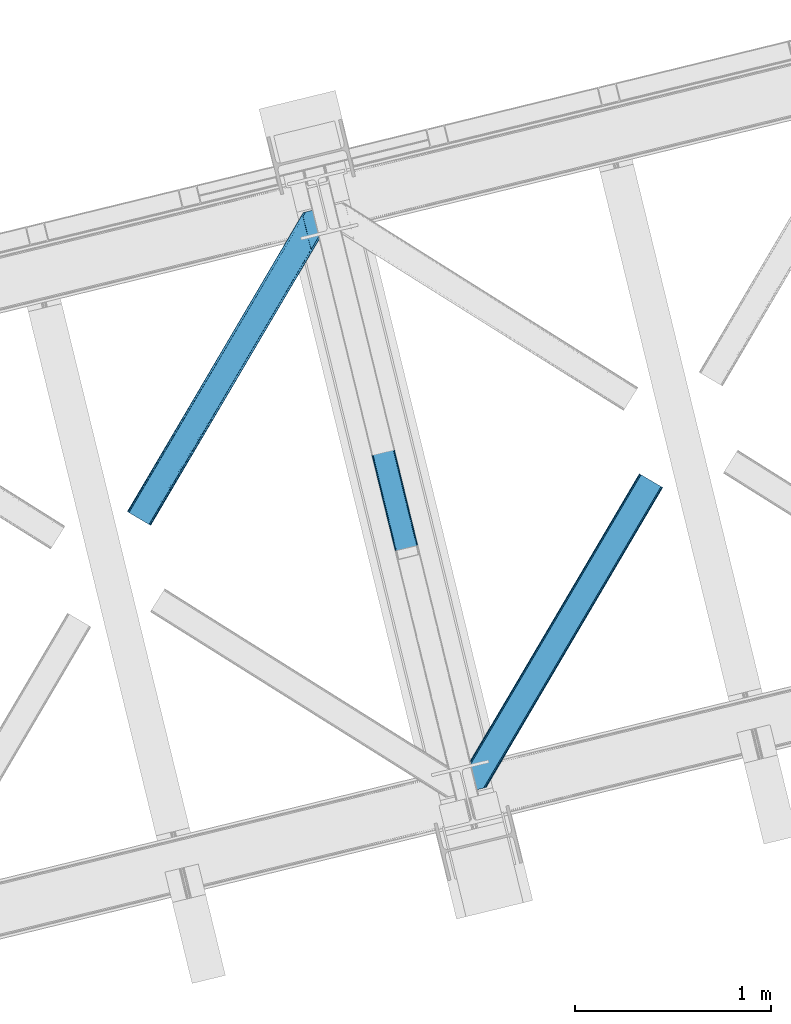
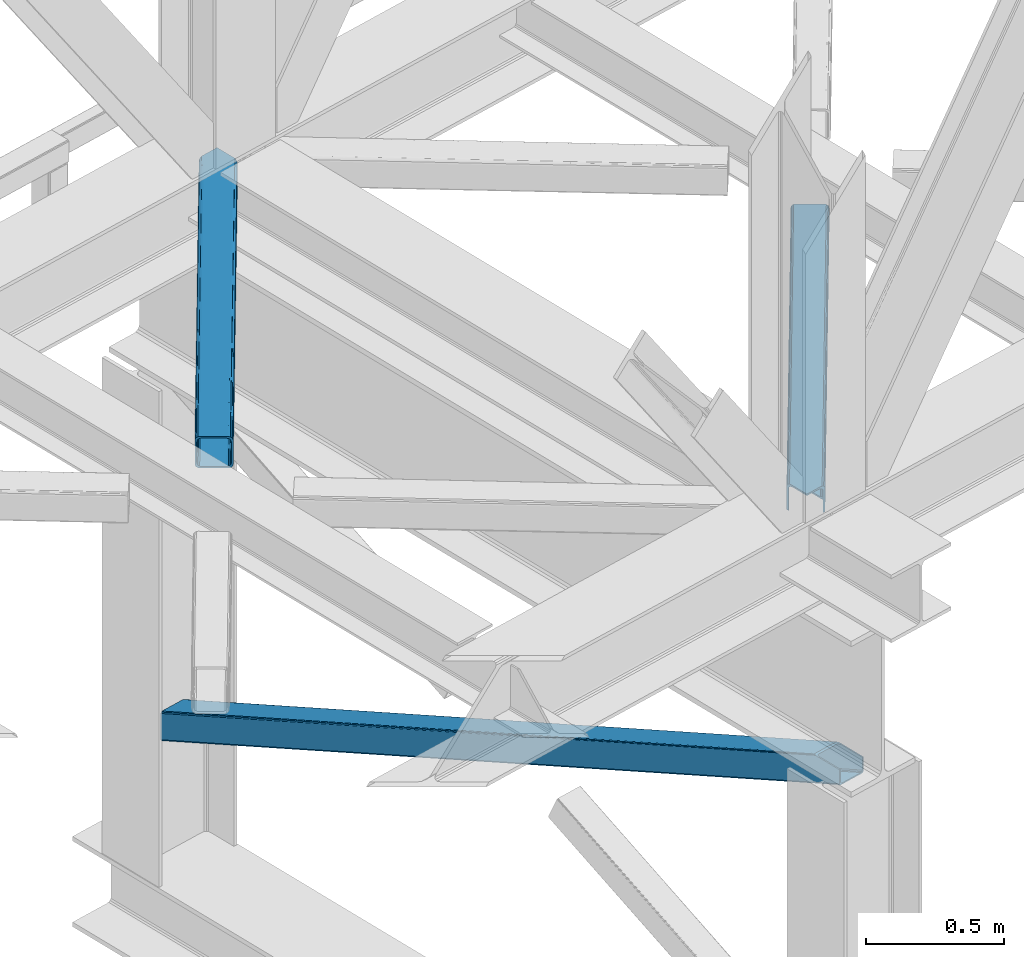
# One storey, part 30 of 92: 3 members.
"""IFC4 building model written with IfcOpenShell, lengths in millimetres."""

from ifc_helpers import new_model, entity, si_unit, converted_unit, derived_unit, direction, frame, origin, place, context, subcontext, project, spatial, triangles, type_object, element, save


model = new_model("IFC4")

# Units and contexts
model_context = context("Model", 3, precision=0.01, world=origin(), true_north=direction((6.12303176911189e-17, 1.0)))
plan_context = context("Plan", 3, precision=0.01, world=origin(), true_north=direction((6.12303176911189e-17, 1.0)))
body_context = subcontext(model_context, "Body", "Model", "MODEL_VIEW")
ifc_project = project(units=[si_unit("LENGTHUNIT", "METRE", prefix="MILLI"), si_unit("AREAUNIT", "SQUARE_METRE"), si_unit("VOLUMEUNIT", "CUBIC_METRE"), converted_unit("PLANEANGLEUNIT", "DEGREE", entity("IfcRatioMeasure", 0.0174532925199433), si_unit("PLANEANGLEUNIT", "RADIAN"), dimensions=[0, 0, 0, 0, 0, 0, 0]), si_unit("MASSUNIT", "GRAM", prefix="KILO"), derived_unit("MASSDENSITYUNIT", [(si_unit("MASSUNIT", "GRAM", prefix="KILO"), 1), (si_unit("LENGTHUNIT", "METRE"), -3)]), derived_unit("MOMENTOFINERTIAUNIT", [(si_unit("LENGTHUNIT", "METRE"), 4)]), si_unit("TIMEUNIT", "SECOND"), si_unit("FREQUENCYUNIT", "HERTZ"), si_unit("THERMODYNAMICTEMPERATUREUNIT", "DEGREE_CELSIUS"), derived_unit("THERMALTRANSMITTANCEUNIT", [(si_unit("MASSUNIT", "GRAM", prefix="KILO"), 1), (si_unit("THERMODYNAMICTEMPERATUREUNIT", "KELVIN"), -1), (si_unit("TIMEUNIT", "SECOND"), -3)]), derived_unit("VOLUMETRICFLOWRATEUNIT", [(si_unit("LENGTHUNIT", "METRE"), 3), (si_unit("TIMEUNIT", "SECOND"), -1)]), derived_unit("MASSFLOWRATEUNIT", [(si_unit("MASSUNIT", "GRAM", prefix="KILO"), 1), (si_unit("TIMEUNIT", "SECOND"), -1)]), derived_unit("ROTATIONALFREQUENCYUNIT", [(si_unit("TIMEUNIT", "SECOND"), -1)]), si_unit("ELECTRICCURRENTUNIT", "AMPERE"), si_unit("ELECTRICVOLTAGEUNIT", "VOLT"), si_unit("POWERUNIT", "WATT"), si_unit("FORCEUNIT", "NEWTON", prefix="KILO"), si_unit("ILLUMINANCEUNIT", "LUX"), si_unit("LUMINOUSFLUXUNIT", "LUMEN"), si_unit("LUMINOUSINTENSITYUNIT", "CANDELA"), derived_unit("USERDEFINED", [(si_unit("MASSUNIT", "GRAM", prefix="KILO"), -1), (si_unit("LENGTHUNIT", "METRE"), -2), (si_unit("TIMEUNIT", "SECOND"), 3), (si_unit("LUMINOUSFLUXUNIT", "LUMEN"), 1)]), derived_unit("LINEARVELOCITYUNIT", [(si_unit("LENGTHUNIT", "METRE"), 1), (si_unit("TIMEUNIT", "SECOND"), -1)]), si_unit("PRESSUREUNIT", "PASCAL"), derived_unit("USERDEFINED", [(si_unit("LENGTHUNIT", "METRE"), -2), (si_unit("MASSUNIT", "GRAM", prefix="KILO"), 1), (si_unit("TIMEUNIT", "SECOND"), -2)]), derived_unit("LINEARFORCEUNIT", [(si_unit("MASSUNIT", "GRAM", prefix="KILO"), 1), (si_unit("LENGTHUNIT", "METRE"), 1), (si_unit("TIMEUNIT", "SECOND"), -2), (si_unit("LENGTHUNIT", "METRE"), -1)]), derived_unit("PLANARFORCEUNIT", [(si_unit("MASSUNIT", "GRAM", prefix="KILO"), 1), (si_unit("LENGTHUNIT", "METRE"), 1), (si_unit("TIMEUNIT", "SECOND"), -2), (si_unit("LENGTHUNIT", "METRE"), -2)])], contexts=[model_context, plan_context])

# Site, building, storey
site_placement = place(None, origin())
site = spatial("IfcSite", under=ifc_project, at=site_placement, CompositionType="ELEMENT")
building_placement = place(site_placement, origin())
building = spatial("IfcBuilding", under=site, at=building_placement, CompositionType="ELEMENT")
storey_placement = place(building_placement, frame((0.0, 0.0, 15900.0)))
storey = spatial("IfcBuildingStorey", under=building, at=storey_placement, Name="05", CompositionType="ELEMENT", Elevation=15900.0)

# Members
member_type_1 = type_object("IfcMemberType", PredefinedType="BRACE")
member_1_placement = place(storey_placement, frame((-55294.26, 4087.91, 911.28)))
element("IfcMember", 1, at=member_1_placement, inside=storey, type_object=member_type_1, ObjectType="Steel Vertical Brace", PredefinedType="BRACE", context=body_context, shape_type="Tessellation", body=[
    triangles([(109.783996582031, 3493.74488525391, 0.0), (954.899853515621, 26.7611572265623, 1610.78191223144), (6.79958496093604, 3468.64118499756, 0.0), (851.915441894525, 1.65774765014658, 1610.78191223144), (112.188500976561, 3494.33089599609, 1.12551269531104), (957.30435791015, 27.3474586486818, 1611.90626220703), (114.593005371091, 3494.91690673828, 2.24986267089844), (959.708862304688, 27.9334693908695, 1613.03061218261), (115.588293457025, 3495.15991516113, 4.96481323242188), (960.704150390622, 28.1761871337894, 1615.74672546387), (116.588232421869, 3495.40234222412, 7.68092651366896), (961.699438476557, 28.4189048767093, 1618.46167602539), (0.99528808593459, 3467.22615509033, 4.96481323242188), (846.111145019531, 0.242717742919922, 1615.74672546387), (0.0, 3466.98372802734, 7.68092651366896), (845.115856933589, 0.0, 1618.46167602539), (1.99057617186918, 3467.46916351318, 2.24986267089844), (847.106433105466, 0.485435485839844, 1613.03061218261), (4.39508056640625, 3468.05517425537, 1.12551269531104), (849.510937499996, 1.07144622802753, 1611.90626220703), (933.347680664061, 144.732444763184, 1680.7206665039), (116.588232421869, 3495.40234222412, 123.979641723632), (961.699438476557, 28.4189048767093, 1680.7206665039), (816.759448242185, 116.313539886474, 1680.7206665039), (0.0, 3466.98372802734, 123.979641723632), (845.115856933589, 0.0, 1680.7206665039), (112.188500976561, 3494.33089599609, 130.53505554199), (109.783996582031, 3493.74488525391, 131.659405517577), (922.5157836914, 159.605083465576, 1680.7206665039), (114.593005371091, 3494.91690673828, 129.409542846679), (925.427233886716, 158.980993652343, 1680.7206665039), (115.588293457025, 3495.15991516113, 126.694592285156), (928.506115722652, 155.935830688477, 1680.7206665039), (931.287341308591, 150.932357025146, 1680.7206665039), (6.79958496093604, 3468.64118499756, 131.659405517577), (819.531372070313, 134.501383209228, 1680.7206665039), (815.73625488281, 122.76547164917, 1680.7206665039), (0.99528808593459, 3467.22615509033, 126.694592285156), (815.903686523438, 128.487506103515, 1680.7206665039), (1.99057617186918, 3467.46916351318, 129.409542846679), (817.23848876953, 132.608766174317, 1680.7206665039), (4.39508056640625, 3468.05517425537, 130.53505554199), (923.44595947265, 145.989635467529, 1680.7206665039), (926.524841308594, 142.94418182373, 1680.7206665039), (920.539160156244, 146.61343460083, 1680.7206665039), (931.366406249996, 131.74108657837, 1680.7206665039), (956.843920898435, 27.2349655151365, 1680.7206665039), (929.306066894525, 137.9407081604, 1680.7206665039), (823.638098144525, 117.864317321777, 1680.7206665039), (824.972900390625, 121.985577392578, 1680.7206665039), (827.27043457031, 123.878194427491, 1680.7206665039), (824.498510742182, 105.690060424805, 1680.7206665039), (823.475317382807, 112.142282867431, 1680.7206665039), (849.971374511719, 1.18393936157236, 1680.7206665039), (111.728063964838, 3494.21869354248, 118.492767333984), (110.732775878903, 3493.97568511963, 121.208880615231), (109.737487792969, 3493.73267669678, 123.923831176755), (107.332983398432, 3493.14666595459, 125.048181152342), (104.928479003902, 3492.5606552124, 126.173693847653), (11.6597534179673, 3469.82541503906, 126.173693847653), (9.2552490234375, 3469.23940429688, 125.048181152342), (6.85074462890043, 3468.65339355469, 123.923831176755), (5.85545654296584, 3468.41038513184, 121.208880615231), (4.85551757812209, 3468.16737670898, 118.492767333984), (111.728063964838, 3494.21869354248, 13.166638183593), (956.843920898435, 27.2349655151365, 1623.94738769531), (4.85551757812209, 3468.16737670898, 13.166638183593), (849.971374511719, 1.18393936157236, 1623.94738769531), (109.737487792969, 3493.73267669678, 7.73557434081886), (107.332983398432, 3493.14666595459, 6.61122436523146), (110.732775878903, 3493.97568511963, 10.4505249023423), (104.928479003902, 3492.5606552124, 5.48571166992042), (6.85074462890043, 3468.65339355469, 7.73557434081886), (5.85545654296584, 3468.41038513184, 10.4505249023423), (9.2552490234375, 3469.23940429688, 6.61122436523146), (11.6597534179673, 3469.82541503906, 5.48571166992042), (950.039685058589, 25.5772178649904, 1616.26762390137), (952.444189453119, 26.1632286071781, 1617.39197387695), (954.848693847656, 26.7492393493649, 1618.51748657227), (856.770959472655, 2.8419776916503, 1616.26762390137), (854.366455078125, 2.25567626953125, 1617.39197387695), (851.961950683588, 1.66966552734357, 1618.51748657227), (955.8486328125, 26.9922477722166, 1621.23243713379), (850.966662597653, 1.42665710449228, 1621.23243713379)], [[1, 2, 3], [4, 3, 2], [5, 6, 2], [2, 1, 5], [7, 8, 6], [6, 5, 7], [9, 10, 8], [8, 7, 9], [11, 12, 10], [10, 9, 11], [13, 14, 15], [16, 15, 14], [17, 18, 13], [14, 13, 18], [19, 20, 17], [18, 17, 20], [3, 4, 19], [20, 19, 4], [11, 21, 12], [21, 11, 22], [23, 12, 21], [24, 15, 16], [24, 25, 15], [16, 26, 24], [27, 28, 29], [30, 27, 31], [32, 30, 33], [22, 32, 34], [34, 21, 22], [33, 34, 32], [31, 33, 30], [29, 31, 27], [29, 28, 35], [35, 36, 29], [25, 24, 37], [38, 37, 39], [40, 39, 41], [42, 41, 36], [36, 35, 42], [41, 42, 40], [39, 40, 38], [37, 38, 25], [43, 44, 34], [33, 43, 34], [29, 33, 31], [45, 29, 36], [33, 45, 43], [29, 45, 33], [44, 21, 34], [23, 46, 47], [23, 21, 46], [44, 48, 21], [48, 46, 21], [37, 49, 50], [36, 51, 45], [51, 39, 50], [39, 51, 36], [50, 39, 37], [39, 36, 41], [24, 49, 37], [52, 53, 24], [53, 49, 24], [52, 26, 54], [24, 26, 52], [55, 46, 48], [56, 48, 44], [57, 44, 43], [58, 43, 45], [45, 59, 58], [43, 58, 57], [44, 57, 56], [48, 56, 55], [59, 45, 51], [51, 60, 59], [61, 60, 51], [62, 61, 50], [63, 62, 49], [64, 63, 53], [53, 52, 64], [49, 53, 63], [50, 49, 62], [51, 50, 61], [46, 65, 66], [46, 55, 65], [66, 47, 46], [67, 52, 68], [52, 67, 64], [54, 68, 52], [58, 59, 28], [32, 57, 27], [32, 27, 30], [28, 59, 35], [28, 27, 58], [57, 58, 27], [55, 22, 11], [22, 56, 57], [55, 56, 22], [22, 57, 32], [42, 62, 38], [60, 35, 59], [61, 42, 35], [61, 35, 60], [38, 40, 42], [62, 25, 38], [42, 61, 62], [62, 63, 25], [25, 64, 15], [64, 25, 63], [69, 5, 70], [11, 65, 55], [71, 11, 69], [11, 71, 65], [69, 11, 9], [70, 1, 72], [69, 9, 5], [5, 9, 7], [72, 1, 3], [5, 1, 70], [73, 13, 15], [74, 73, 15], [75, 19, 73], [67, 15, 64], [15, 67, 74], [19, 13, 73], [3, 76, 72], [19, 75, 3], [76, 3, 75], [17, 13, 19], [77, 4, 2], [2, 6, 78], [6, 8, 10], [6, 79, 78], [2, 78, 77], [79, 6, 10], [80, 4, 77], [18, 20, 14], [20, 4, 81], [81, 82, 20], [20, 82, 14], [80, 81, 4], [14, 82, 16], [83, 12, 66], [10, 12, 79], [83, 79, 12], [23, 66, 12], [23, 47, 66], [16, 84, 68], [84, 16, 82], [68, 26, 16], [26, 68, 54], [77, 72, 76], [76, 80, 77], [66, 65, 83], [71, 83, 65], [83, 71, 79], [69, 79, 71], [79, 69, 78], [70, 78, 69], [78, 70, 77], [72, 77, 70], [80, 76, 75], [75, 81, 80], [81, 75, 73], [73, 82, 81], [82, 73, 74], [74, 84, 82], [84, 74, 67], [67, 68, 84]]),
])
member_type_2 = type_object("IfcMemberType", PredefinedType="BRACE")
member_2_placement = place(storey_placement, frame((-56177.58, 5705.47, 3511.0)))
element("IfcMember", 2, at=member_2_placement, inside=storey, type_object=member_type_2, ObjectType="Steel Horizontal Brace", PredefinedType="BRACE", context=body_context, shape_type="Tessellation", body=[
    triangles([(105.560998535155, 8.87794647216833, 0.0), (15.078149414061, 62.148532104492, 0.0), (892.843176269533, 1346.13992614746, 0.0), (857.166284179686, 1492.50250396729, 0.0), (854.892004394533, 1501.83739929199, 1.33247680664135), (9.30640869140916, 65.5459991455082, 1.33247680664135), (852.961889648439, 1509.75145111084, 5.12526855468968), (4.41368408202834, 68.4266372680668, 5.12526855468968), (851.673596191409, 1515.03950042725, 10.8028289794929), (1.14411621094041, 70.3509384155277, 10.8028289794929), (851.222460937497, 1516.89636383057, 17.5000946044929), (0.0, 71.0270599365231, 17.5000946044929), (893.633825683595, 1342.89768218994, 0.155804443362285), (111.332739257814, 5.48047943115216, 1.33247680664135), (899.559045410155, 1344.34178009033, 1.33247680664135), (912.390820312503, 1347.46949615478, 10.8028289794929), (914.195361328122, 1347.90958557129, 17.5000946044929), (120.643798828125, 0.0, 17.5000946044929), (119.495031738283, 0.675540161132631, 10.8028289794929), (907.251599121097, 1346.21666564941, 5.12526855468968), (116.225463867188, 2.60042266845721, 5.12526855468968), (902.493750000001, 1345.05743408203, 17.9802978515654), (893.633825683595, 1342.89768218994, 9.69243164062573), (897.763806152347, 1343.90459747314, 12.1260040283232), (903.721582031249, 1345.35683441162, 19.4999725341804), (914.195361328122, 1347.90958557129, 19.4999725341804), (1011.61732177735, 1513.38669433594, 19.4999725341804), (1008.98957519532, 1524.16103668213, 19.4999725341804), (1011.61732177735, 1513.38669433594, 122.500662231447), (120.643798828125, 0.0, 122.500662231447), (114.61160888672, 3.55094604492206, 24.4996673583992), (1009.23607177734, 1523.14423828125, 24.4996673583992), (113.462841796878, 4.22706756591833, 17.8035644531265), (110.193273925783, 6.15136871337927, 12.1260040283232), (105.300549316409, 9.03200683593786, 8.3320495605476), (99.52880859375, 12.4294738769531, 6.99957275390625), (892.685046386716, 1346.79976959229, 8.88434143066479), (890.466577148436, 1355.89747009277, 6.99957275390625), (21.1103393554658, 58.5970046997072, 6.99957275390625), (859.547534179685, 1482.74496002197, 6.99957275390625), (853.961828613283, 1505.66042175293, 18.5000335693367), (851.222460937497, 1516.89636383057, 18.5000335693367), (854.092053222659, 1505.10871124268, 17.8803039550803), (855.338488769528, 1499.99390716553, 12.1260040283232), (857.268603515622, 1492.07985534668, 8.3320495605476), (1009.23607177734, 1523.14423828125, 115.501089477541), (114.61160888672, 3.55094604492206, 115.501089477541), (1008.78493652344, 1525.00110168457, 122.196029663086), (113.462841796878, 4.22706756591833, 122.196029663086), (1007.49664306641, 1530.28856964111, 127.87475280762), (110.193273925783, 6.15136871337927, 127.87475280762), (1005.56652832031, 1538.20262145996, 131.667544555665), (105.300549316409, 9.03200683593786, 131.667544555665), (1003.29224853516, 1547.53809814453, 133.000021362306), (99.52880859375, 12.4294738769531, 133.000021362306), (851.947998046875, 1518.13291625977, 19.4999725341804), (854.575744628906, 1507.35857391357, 19.4999725341804), (851.775915527345, 1517.83991088867, 19.2639404296897), (854.426916503908, 1506.95045928955, 19.2592895507842), (851.585229492186, 1517.51434936523, 19.0000030517585), (854.268786621091, 1506.50920715332, 19.0000030517585), (851.394543457034, 1517.1887878418, 18.736065673831), (854.106005859372, 1506.06795501709, 18.7407165527366), (908.014343261719, 1598.12628936768, 19.4999725341804), (897.540563964845, 1595.57353820801, 19.4999725341804), (1011.16153564453, 1515.24355773926, 129.197927856447), (1009.8732421875, 1520.53160705566, 134.874325561526), (1008.43146972657, 1526.45624542236, 137.999716186525), (986.307238769528, 1617.21117095947, 137.999716186525), (986.307238769528, 1617.21117095947, 133.000021362306), (897.540563964845, 1595.57353820801, 122.500662231447), (0.0, 71.0270599365231, 122.500662231447), (7.17630615234521, 66.799411010742, 17.8035644531265), (10.4458740234404, 64.8751098632811, 12.1260040283232), (6.03218994140479, 67.4755325317383, 24.4996673583992), (907.023706054686, 1597.88560638428, 24.4996673583992), (15.338598632814, 61.9944717407225, 8.3320495605476), (908.828247070313, 1598.32511444092, 122.196029663086), (899.345104980472, 1596.01362762451, 129.197927856447), (904.484326171878, 1597.26645812988, 134.874325561526), (930.73388671875, 1603.66490478516, 133.000021362306), (910.24211425781, 1598.66986083984, 137.999716186525), (921.660021972653, 1601.45341186523, 131.667544555665), (913.967468261719, 1599.57852630615, 127.87475280762), (907.023706054686, 1597.88560638428, 115.501089477541), (21.1103393554658, 58.5970046997072, 133.000021362306), (6.03218994140479, 67.4755325317383, 115.501089477541), (15.338598632814, 61.9944717407225, 131.667544555665), (10.4458740234404, 64.8751098632811, 127.87475280762), (7.17630615234521, 66.799411010742, 122.196029663086), (119.495031738283, 0.675540161132631, 129.197927856447), (116.225463867188, 2.60042266845721, 134.874325561526), (111.332739257814, 5.48047943115216, 138.667117309571), (105.560998535155, 8.87794647216833, 139.999594116212), (15.078149414061, 62.148532104492, 139.999594116212), (9.30640869140916, 65.5459991455082, 138.667117309571), (4.41368408202834, 68.4266372680668, 134.874325561526), (1.14411621094041, 70.3509384155277, 129.197927856447), (896.987109374997, 1576.15553741455, 137.999716186525), (938.18924560547, 1407.14434204102, 137.999716186525), (899.019543457034, 1563.59525756836, 139.999594116212), (897.038269042969, 1571.72266845703, 138.999655151369), (896.796423339845, 1573.13653564453, 138.639212036134), (896.926647949222, 1575.15443572998, 138.211331176761), (896.86153564453, 1574.14112548828, 138.427597045898), (937.473010253903, 1407.08562469482, 138.29272155762), (937.077685546872, 1408.09486541748, 138.646188354494), (936.682360839841, 1409.10410614014, 138.999655151369), (934.701086425783, 1417.23267974853, 139.999594116212)], [[1, 2, 3], [4, 3, 2], [5, 4, 6], [2, 6, 4], [7, 5, 8], [6, 8, 5], [9, 7, 10], [8, 10, 7], [11, 9, 12], [10, 12, 9], [1, 3, 13], [13, 14, 1], [13, 15, 14], [16, 17, 18], [18, 19, 16], [20, 16, 19], [19, 21, 20], [15, 20, 21], [21, 14, 15], [20, 22, 16], [23, 24, 15], [23, 15, 13], [15, 24, 20], [16, 25, 17], [20, 24, 22], [16, 22, 25], [26, 17, 25], [26, 25, 27], [28, 27, 25], [27, 29, 26], [30, 26, 29], [26, 18, 17], [30, 18, 26], [31, 32, 25], [25, 33, 31], [25, 22, 33], [32, 28, 25], [33, 22, 24], [34, 24, 23], [23, 35, 34], [36, 35, 37], [37, 38, 36], [23, 37, 35], [24, 34, 33], [39, 36, 38], [38, 40, 39], [9, 11, 41], [11, 42, 41], [43, 9, 41], [43, 7, 9], [44, 7, 43], [5, 44, 45], [44, 5, 7], [4, 5, 45], [45, 40, 4], [37, 23, 13], [37, 3, 38], [3, 40, 38], [40, 3, 4], [37, 13, 3], [46, 32, 31], [31, 47, 46], [48, 46, 49], [47, 49, 46], [50, 48, 51], [49, 51, 48], [52, 50, 53], [51, 53, 50], [54, 52, 55], [53, 55, 52], [56, 57, 58], [59, 58, 57], [58, 59, 60], [61, 60, 59], [60, 61, 62], [63, 62, 61], [62, 63, 42], [41, 42, 63], [57, 56, 64], [65, 64, 56], [66, 48, 67], [46, 29, 27], [27, 32, 46], [32, 27, 28], [48, 29, 46], [66, 29, 48], [50, 68, 67], [52, 68, 50], [67, 48, 50], [52, 54, 68], [54, 69, 68], [70, 69, 54], [71, 60, 62], [58, 60, 71], [71, 56, 58], [56, 71, 65], [42, 12, 72], [12, 42, 11], [71, 42, 72], [42, 71, 62], [73, 74, 44], [75, 73, 43], [43, 41, 75], [43, 57, 75], [64, 76, 57], [75, 57, 76], [44, 43, 73], [45, 44, 74], [74, 77, 45], [40, 45, 77], [77, 39, 40], [78, 79, 80], [81, 82, 69], [69, 70, 81], [81, 83, 82], [84, 82, 83], [80, 82, 84], [78, 71, 79], [85, 71, 78], [80, 84, 78], [65, 76, 64], [85, 65, 71], [76, 65, 85], [86, 54, 55], [54, 86, 81], [70, 54, 81], [76, 85, 87], [87, 75, 76], [83, 81, 86], [86, 88, 83], [84, 83, 88], [88, 89, 84], [78, 84, 89], [89, 90, 78], [85, 78, 90], [90, 87, 85], [91, 51, 49], [47, 18, 30], [91, 49, 30], [91, 92, 51], [49, 47, 30], [51, 92, 93], [55, 94, 95], [94, 53, 93], [53, 94, 55], [53, 51, 93], [19, 34, 21], [31, 18, 47], [18, 33, 19], [33, 18, 31], [19, 33, 34], [1, 36, 2], [14, 21, 34], [34, 35, 14], [35, 36, 1], [1, 14, 35], [89, 96, 97], [95, 86, 55], [95, 88, 86], [88, 95, 96], [89, 88, 96], [87, 72, 12], [98, 90, 89], [97, 98, 89], [90, 98, 72], [87, 90, 72], [6, 74, 8], [2, 36, 39], [39, 77, 2], [77, 74, 6], [6, 2, 77], [10, 8, 74], [12, 75, 87], [73, 12, 10], [12, 73, 75], [73, 10, 74], [99, 68, 82], [99, 100, 68], [68, 69, 82], [96, 95, 101], [101, 102, 96], [97, 96, 103], [104, 97, 105], [104, 99, 97], [97, 103, 105], [82, 80, 99], [97, 99, 80], [102, 103, 96], [79, 71, 98], [72, 98, 71], [80, 79, 97], [98, 97, 79], [92, 67, 100], [100, 93, 92], [67, 68, 100], [106, 107, 93], [94, 93, 107], [107, 108, 94], [108, 109, 94], [66, 67, 92], [92, 91, 66], [29, 66, 91], [91, 30, 29], [95, 94, 109], [109, 101, 95], [107, 103, 102], [105, 103, 107], [106, 104, 105], [100, 99, 104], [107, 106, 105], [102, 108, 107], [102, 101, 109], [109, 108, 102]]),
])
member_type_3 = type_object("IfcMemberType", PredefinedType="BRACE")
member_3_placement = place(storey_placement, frame((-54460.74, 4348.58, 3511.0)))
element("IfcMember", 3, at=member_3_placement, inside=storey, type_object=member_type_3, ObjectType="Steel Horizontal Brace", PredefinedType="BRACE", context=body_context, shape_type="Tessellation", body=[
    triangles([(154.451037597661, 124.708957672119, 0.0), (118.774145507814, 271.071535491944, 0.0), (998.971582031256, 1559.19901428223, 0.0), (908.488732910162, 1612.46901855469, 0.0), (1004.74332275391, 1555.80096588135, 1.33247680664135), (156.725317382814, 115.37377166748, 1.33247680664135), (1009.63604736328, 1552.92090911865, 5.12526855468968), (158.655432128908, 107.459719848634, 5.12526855468968), (1012.90561523438, 1550.99602661133, 10.8028289794929), (159.943725585938, 102.171961212159, 10.8028289794929), (1014.05438232422, 1550.3204864502, 17.5000946044929), (160.39486083985, 100.315097808838, 17.5000946044929), (902.716992187503, 1615.8664855957, 1.33247680664135), (116.495214843751, 280.406721496583, 1.33247680664135), (114.579052734378, 288.275717926026, 5.17061462402489), (897.824267578129, 1618.74712371826, 5.12526855468968), (114.499987792973, 288.596628570557, 5.32641906738354), (894.554699707034, 1620.67142486572, 10.8028289794929), (109.630517578131, 287.409491729737, 10.8028289794929), (893.410583496094, 1621.34754638672, 17.5000946044929), (107.825976562504, 286.969402313232, 17.5000946044929), (113.527954101563, 288.360015106202, 18.5197998046897), (114.499987792973, 288.596628570557, 17.5198608398459), (114.42557373047, 288.578606414795, 17.9023956298843), (114.216284179689, 288.527446746826, 18.2279571533218), (113.900024414063, 288.450416564941, 18.4442230224631), (107.825976562504, 286.969402313232, 18.5197998046897), (115.695263671878, 283.683847045899, 17.5198608398459), (115.625500488284, 283.800700378419, 17.8035644531265), (115.569689941411, 283.740529632569, 17.8570495605491), (115.323193359378, 283.495777130127, 18.0768035888686), (115.067395019534, 283.23939743042, 18.3081848144539), (114.834851074222, 283.003365325928, 18.5197998046897), (0.0, 103.824767303468, 18.5197998046897), (2.73936767578562, 92.5989990234375, 18.5197998046897), (893.410583496094, 1621.34754638672, 122.500662231447), (0.0, 103.824767303468, 122.500662231447), (908.488732910162, 1612.46901855469, 139.999594116212), (902.716992187503, 1615.8664855957, 138.667117309571), (3.6741943359375, 88.7660934448249, 138.667117309571), (5.94847412109812, 79.4309074401863, 139.999594116212), (897.824267578129, 1618.74712371826, 134.874325561526), (1.74407958984375, 96.6801452636719, 134.874325561526), (894.554699707034, 1620.67142486572, 129.197927856447), (0.455786132813955, 101.967903900147, 129.197927856447), (899.442773437506, 1617.79601898193, 24.4996673583992), (2.38125000000582, 94.0672233581545, 24.4996673583992), (900.591540527348, 1617.1204788208, 17.8035644531265), (903.856457519534, 1615.19559631348, 12.1260040283232), (914.520922851567, 1608.9174911499, 6.99957275390625), (908.749182128908, 1612.31553955078, 8.3320495605476), (118.87646484375, 270.64917755127, 8.3320495605476), (121.150744628911, 261.313991546631, 6.99957275390625), (116.946350097656, 278.563229370117, 12.1260040283232), (152.069787597662, 134.466501617432, 6.99957275390625), (992.939392089844, 1562.74996032715, 6.99957275390625), (156.274182128909, 117.217263793946, 12.1260040283232), (154.344067382815, 125.131315612794, 8.3320495605476), (157.525268554688, 112.096936798096, 17.5198608398459), (160.39486083985, 100.315097808838, 17.5198608398459), (899.442773437506, 1617.79601898193, 115.501089477541), (2.38125000000582, 94.0672233581545, 115.501089477541), (900.591540527348, 1617.1204788208, 122.196029663086), (2.83238525391062, 92.2103599548345, 122.196029663086), (903.856457519534, 1615.19559631348, 127.87475280762), (4.12067871094041, 86.9226013183597, 127.87475280762), (908.749182128908, 1612.31553955078, 131.667544555665), (6.05079345703416, 79.0085494995119, 131.667544555665), (914.520922851567, 1608.9174911499, 133.000021362306), (8.3250732421875, 69.6736541748051, 133.000021362306), (25.3100830078183, 0.0, 133.000021362306), (25.3100830078183, 0.0, 139.999594116212), (90.3665771484375, 15.8583343505861, 139.999594116212), (998.971582031256, 1559.19901428223, 139.999594116212), (1014.05438232422, 1550.3204864502, 122.500662231447), (1012.90561523438, 1550.99602661133, 129.197927856447), (114.076757812501, 21.6379234313972, 122.500662231447), (112.272216796875, 21.1978340148926, 129.197927856447), (1009.63604736328, 1552.92090911865, 134.874325561526), (107.132995605469, 19.9450035095215, 134.874325561526), (1004.74332275391, 1555.80096588135, 138.667117309571), (99.4404418945342, 18.0698272705085, 138.667117309571), (159.669323730472, 99.0785453796389, 18.5197998046897), (114.076757812501, 21.6379234313972, 18.5197998046897), (103.165795898443, 18.9782020568855, 18.5197998046897), (156.929956054693, 110.3046043396, 18.5197998046897), (1008.02219238281, 1553.87201385498, 24.4996673583992), (1006.87342529297, 1554.54755401611, 17.8035644531265), (157.22761230469, 111.200770568848, 18.0198303222678), (1003.60385742188, 1556.47243652344, 12.1260040283232), (998.711132812503, 1559.35249328613, 8.3320495605476), (104.593615722661, 19.3261459350588, 24.4996673583992), (1003.60385742188, 1556.47243652344, 127.87475280762), (1008.02219238281, 1553.87201385498, 115.501089477541), (1006.87342529297, 1554.54755401611, 122.196029663086), (992.939392089844, 1562.74996032715, 133.000021362306), (998.711132812503, 1559.35249328613, 131.667544555665), (102.789074707034, 18.8860565185551, 122.196029663086), (80.8834350585967, 13.5465568542486, 133.000021362306), (89.9572998046933, 15.7580497741701, 131.667544555665), (97.6498535156279, 17.633226013184, 127.87475280762), (104.593615722661, 19.3261459350588, 115.501089477541)], [[1, 2, 3], [4, 3, 2], [3, 5, 1], [6, 1, 5], [5, 7, 6], [8, 6, 7], [7, 9, 8], [10, 8, 9], [9, 11, 10], [12, 10, 11], [13, 14, 15], [16, 15, 17], [17, 18, 16], [17, 19, 18], [20, 18, 19], [19, 21, 20], [15, 16, 13], [13, 4, 14], [2, 14, 4], [22, 23, 24], [22, 25, 26], [27, 21, 22], [24, 25, 22], [23, 22, 21], [21, 19, 23], [17, 23, 19], [23, 28, 29], [29, 24, 23], [25, 24, 30], [26, 25, 31], [22, 26, 32], [32, 33, 22], [31, 32, 26], [30, 31, 25], [29, 30, 24], [34, 33, 35], [33, 34, 27], [22, 33, 27], [27, 20, 21], [36, 27, 37], [27, 36, 20], [27, 34, 37], [38, 39, 40], [40, 41, 38], [39, 42, 43], [43, 40, 39], [42, 44, 45], [45, 43, 42], [44, 36, 37], [37, 45, 44], [46, 47, 33], [33, 48, 46], [33, 31, 48], [47, 35, 33], [49, 48, 28], [50, 51, 52], [52, 53, 50], [51, 49, 54], [54, 52, 51], [28, 54, 49], [53, 55, 56], [56, 50, 53], [55, 2, 1], [54, 17, 14], [52, 14, 2], [52, 2, 53], [55, 53, 2], [17, 28, 23], [54, 28, 17], [52, 54, 14], [57, 58, 6], [58, 1, 6], [1, 58, 55], [8, 57, 6], [8, 59, 57], [10, 59, 8], [10, 60, 59], [46, 61, 47], [62, 47, 61], [61, 63, 62], [64, 62, 63], [63, 65, 64], [66, 64, 65], [65, 67, 66], [68, 66, 67], [67, 69, 68], [70, 68, 69], [66, 43, 64], [71, 72, 70], [72, 41, 70], [40, 68, 41], [66, 68, 40], [68, 70, 41], [66, 40, 43], [37, 34, 62], [45, 64, 43], [62, 64, 37], [64, 45, 37], [34, 47, 62], [34, 35, 47], [41, 73, 74], [73, 41, 72], [74, 38, 41], [75, 76, 77], [78, 77, 76], [76, 79, 78], [80, 78, 79], [79, 81, 80], [82, 80, 81], [81, 74, 82], [73, 82, 74], [60, 75, 77], [60, 11, 75], [77, 83, 60], [77, 84, 83], [84, 85, 83], [86, 83, 85], [87, 88, 59], [89, 86, 87], [88, 90, 57], [57, 59, 88], [90, 91, 58], [58, 57, 90], [91, 56, 55], [55, 58, 91], [87, 86, 92], [85, 92, 86], [9, 90, 88], [87, 75, 11], [9, 88, 11], [9, 7, 90], [88, 87, 11], [90, 7, 5], [56, 3, 4], [3, 91, 5], [91, 3, 56], [91, 90, 5], [76, 93, 79], [94, 75, 87], [75, 95, 76], [95, 75, 94], [76, 95, 93], [74, 96, 38], [81, 79, 93], [93, 97, 81], [97, 96, 74], [74, 81, 97], [49, 13, 16], [4, 50, 56], [4, 51, 50], [51, 4, 13], [49, 51, 13], [46, 20, 36], [18, 48, 49], [16, 18, 49], [48, 18, 20], [46, 48, 20], [39, 65, 42], [38, 96, 69], [69, 67, 38], [67, 65, 39], [39, 38, 67], [44, 42, 65], [36, 61, 46], [63, 36, 44], [36, 63, 61], [63, 44, 65], [98, 78, 80], [99, 73, 72], [72, 71, 99], [99, 100, 73], [100, 82, 73], [101, 82, 100], [80, 82, 101], [98, 77, 78], [102, 77, 98], [80, 101, 98], [84, 92, 85], [102, 84, 77], [92, 84, 102], [99, 70, 96], [99, 71, 70], [69, 96, 70], [96, 97, 100], [100, 99, 96], [97, 93, 101], [101, 100, 97], [93, 95, 98], [98, 101, 93], [95, 94, 102], [102, 98, 95], [94, 87, 102], [92, 102, 87]]),
])

save(model, "model.ifc")
